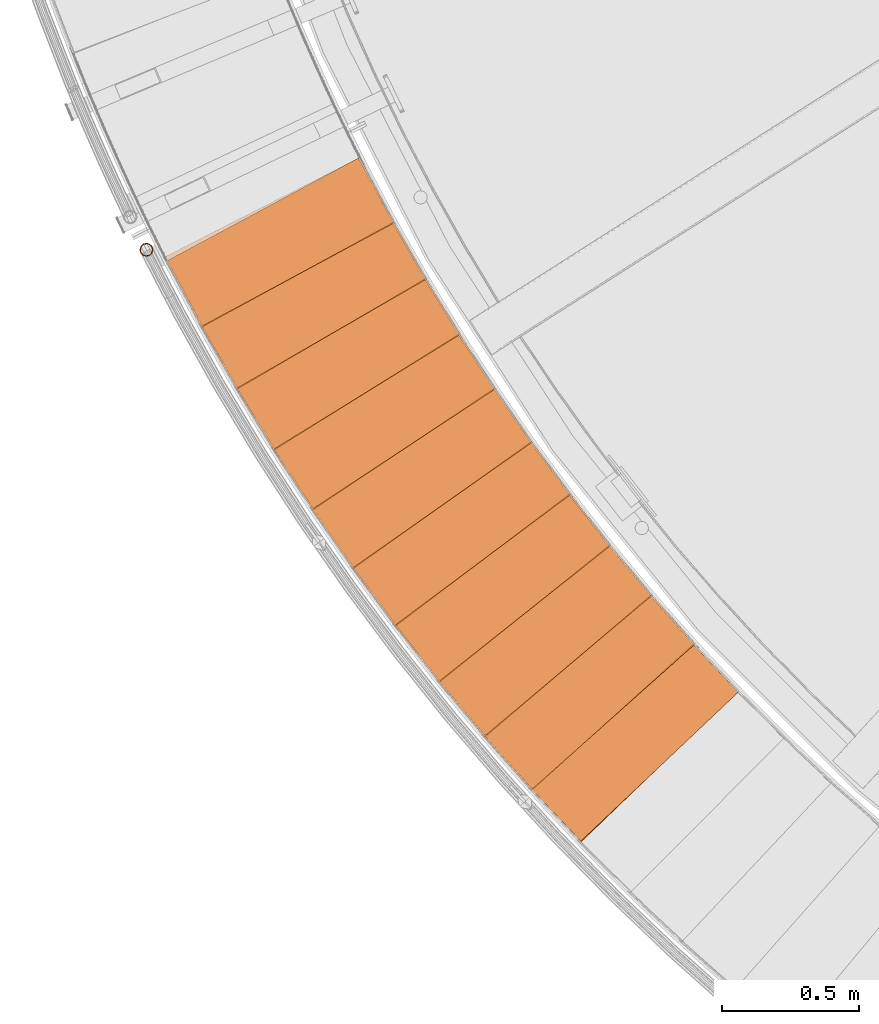
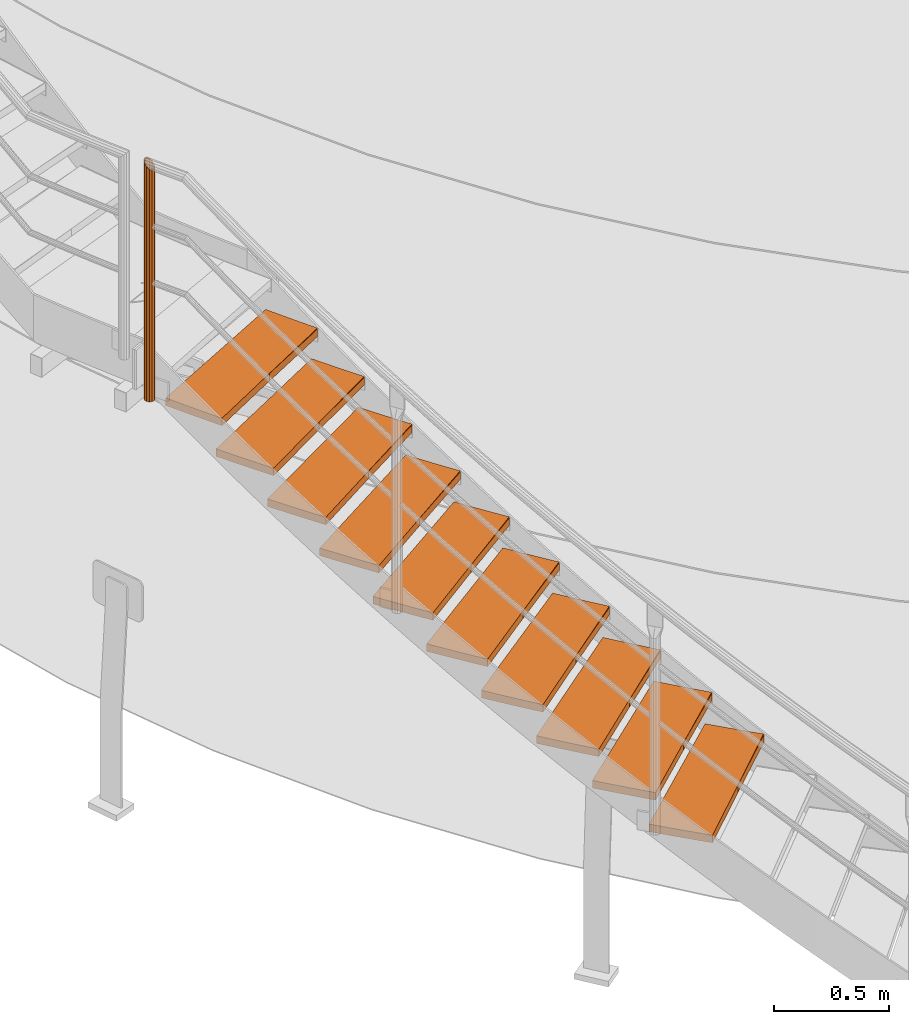
# One storey, part 3 of 126: 21 proxies.
"""IFC2X3 building model written with IfcOpenShell, lengths in millimetres."""

from ifc_helpers import new_model, si_unit, origin, origin_with_axes, place, context, project, spatial, faceted_brep, material, element, save


model = new_model("IFC2X3")

# Units and contexts
context_of_model_1 = context(None, 3, precision=0.1, world=origin())
context_of_model_2 = context(None, 3, precision=0.1, world=origin())
ifc_project = project(units=[si_unit("LENGTHUNIT", "METRE", prefix="MILLI"), si_unit("AREAUNIT", "SQUARE_METRE", prefix="CENTI"), si_unit("VOLUMEUNIT", "CUBIC_METRE", prefix="CENTI"), si_unit("MASSUNIT", "GRAM", prefix="KILO")], contexts=[context_of_model_1, context_of_model_2])

# Site, building, storey
site_placement = place(None, origin_with_axes())
site = spatial("IfcSite", under=ifc_project, at=site_placement, CompositionType="ELEMENT")
building_placement = place(site_placement, origin_with_axes())
building = spatial("IfcBuilding", under=site, at=building_placement, CompositionType="ELEMENT")
storey_placement = place(building_placement, origin_with_axes())
storey = spatial("IfcBuildingStorey", under=building, at=storey_placement, CompositionType="ELEMENT")

# Proxies
ifc_material_1 = material(Name="HOLZ")
proxy_1_placement = place(storey_placement, origin_with_axes())
element("IfcBuildingElementProxy", 1, at=proxy_1_placement, inside=storey, material=ifc_material_1, context=context_of_model_2, shape_type="Brep", body=[
    faceted_brep([(1456.3035, 2101.2672, 1039.2375), (1473.9581, 2081.7425, 1039.2375), (1491.671, 2062.2706, 1039.2375), (1509.442, 2042.8516, 1039.2375), (1527.2708, 2023.4858, 1039.2375), (1545.1574, 2004.1733, 1039.2375), (1563.1016, 1984.9143, 1039.2375), (1581.1032, 1965.7089, 1039.2375), (1599.162, 1946.5574, 1039.2375), (1617.2779, 1927.4599, 1039.2375), (1635.4508, 1908.4165, 1039.2375), (1653.6804, 1889.4275, 1039.2375), (2229.9599, 2444.3167, 1039.2375), (2211.5414, 2463.5088, 1039.2375), (2193.1867, 2482.7619, 1039.2375), (2174.896, 2502.0758, 1039.2375), (2156.6695, 2521.4503, 1039.2375), (2138.5074, 2540.8851, 1039.2375), (2120.4098, 2560.3802, 1039.2375), (2102.377, 2579.9351, 1039.2375), (2084.4092, 2599.5498, 1039.2375), (2066.5066, 2619.224, 1039.2375), (2048.6694, 2638.9574, 1039.2375), (1456.3035, 2101.2672, 999.2375), (2048.6694, 2638.9574, 999.2375), (2066.5066, 2619.224, 999.2375), (2084.4092, 2599.5498, 999.2375), (2102.377, 2579.9351, 999.2375), (2120.4098, 2560.3802, 999.2375), (2138.5074, 2540.8851, 999.2375), (2156.6695, 2521.4503, 999.2375), (2174.896, 2502.0758, 999.2375), (2193.1867, 2482.7619, 999.2375), (2211.5414, 2463.5088, 999.2375), (2229.9599, 2444.3167, 999.2375), (1653.6804, 1889.4275, 999.2375), (1635.4508, 1908.4165, 999.2375), (1617.2779, 1927.4599, 999.2375), (1599.162, 1946.5574, 999.2375), (1581.1032, 1965.7089, 999.2375), (1563.1016, 1984.9143, 999.2375), (1545.1574, 2004.1733, 999.2375), (1527.2708, 2023.4858, 999.2375), (1509.442, 2042.8516, 999.2375), (1491.671, 2062.2706, 999.2375), (1473.9581, 2081.7425, 999.2375)], [[[0, 1, 2, 3, 4, 5, 6, 7, 8, 9, 10, 11, 12, 13, 14, 15, 16, 17, 18, 19, 20, 21, 22]], [[23, 24, 25, 26, 27, 28, 29, 30, 31, 32, 33, 34, 35, 36, 37, 38, 39, 40, 41, 42, 43, 44, 45]], [[0, 23, 45, 1]], [[1, 45, 44, 2]], [[2, 44, 43, 3]], [[3, 43, 42, 4]], [[4, 42, 41, 5]], [[5, 41, 40, 6]], [[6, 40, 39, 7]], [[7, 39, 38, 8]], [[8, 38, 37, 9]], [[9, 37, 36, 10]], [[10, 36, 35, 11]], [[11, 35, 34, 12]], [[12, 34, 33, 13]], [[13, 33, 32, 14]], [[14, 32, 31, 15]], [[15, 31, 30, 16]], [[16, 30, 29, 17]], [[17, 29, 28, 18]], [[18, 28, 27, 19]], [[19, 27, 26, 20]], [[20, 26, 25, 21]], [[21, 25, 24, 22]], [[22, 24, 23, 0]]]),
])
proxy_2_placement = place(storey_placement, origin_with_axes())
element("IfcBuildingElementProxy", 2, at=proxy_2_placement, inside=storey, material=ifc_material_1, context=context_of_model_2, shape_type="Brep", body=[
    faceted_brep([(1285.3726, 2296.5769, 1212.4437), (1302.445, 2276.541, 1212.4437), (1319.5771, 2256.5561, 1212.4437), (1336.7688, 2236.6225, 1212.4437), (1354.0199, 2216.7403, 1212.4437), (1371.3303, 2196.9097, 1212.4437), (1388.6998, 2177.1309, 1212.4437), (1406.1283, 2157.404, 1212.4437), (1423.6156, 2137.7292, 1212.4437), (1441.1616, 2118.1068, 1212.4437), (1458.7661, 2098.5368, 1212.4437), (1476.4289, 2079.0194, 1212.4437), (2068.791, 2616.7062, 1212.4437), (2050.9454, 2636.4321, 1212.4437), (2033.1654, 2656.2171, 1212.4437), (2015.4511, 2676.061, 1212.4437), (1997.8027, 2695.9636, 1212.4437), (1980.2205, 2715.9246, 1212.4437), (1962.7046, 2735.9438, 1212.4437), (1945.2552, 2756.0211, 1212.4437), (1927.8725, 2776.1561, 1212.4437), (1910.5567, 2796.3487, 1212.4437), (1893.3081, 2816.5986, 1212.4437), (1285.3726, 2296.5769, 1172.4437), (1893.3081, 2816.5986, 1172.4437), (1910.5567, 2796.3487, 1172.4437), (1927.8725, 2776.1561, 1172.4437), (1945.2552, 2756.0211, 1172.4437), (1962.7046, 2735.9438, 1172.4437), (1980.2205, 2715.9246, 1172.4437), (1997.8027, 2695.9636, 1172.4437), (2015.4511, 2676.061, 1172.4437), (2033.1654, 2656.2171, 1172.4437), (2050.9454, 2636.4321, 1172.4437), (2068.791, 2616.7062, 1172.4437), (1476.4289, 2079.0194, 1172.4437), (1458.7661, 2098.5368, 1172.4437), (1441.1616, 2118.1068, 1172.4437), (1423.6156, 2137.7292, 1172.4437), (1406.1283, 2157.404, 1172.4437), (1388.6998, 2177.1309, 1172.4437), (1371.3303, 2196.9097, 1172.4437), (1354.0199, 2216.7403, 1172.4437), (1336.7688, 2236.6225, 1172.4437), (1319.5771, 2256.5561, 1172.4437), (1302.445, 2276.541, 1172.4437)], [[[0, 1, 2, 3, 4, 5, 6, 7, 8, 9, 10, 11, 12, 13, 14, 15, 16, 17, 18, 19, 20, 21, 22]], [[23, 24, 25, 26, 27, 28, 29, 30, 31, 32, 33, 34, 35, 36, 37, 38, 39, 40, 41, 42, 43, 44, 45]], [[0, 23, 45, 1]], [[1, 45, 44, 2]], [[2, 44, 43, 3]], [[3, 43, 42, 4]], [[4, 42, 41, 5]], [[5, 41, 40, 6]], [[6, 40, 39, 7]], [[7, 39, 38, 8]], [[8, 38, 37, 9]], [[9, 37, 36, 10]], [[10, 36, 35, 11]], [[11, 35, 34, 12]], [[12, 34, 33, 13]], [[13, 33, 32, 14]], [[14, 32, 31, 15]], [[15, 31, 30, 16]], [[16, 30, 29, 17]], [[17, 29, 28, 18]], [[18, 28, 27, 19]], [[19, 27, 26, 20]], [[20, 26, 25, 21]], [[21, 25, 24, 22]], [[22, 24, 23, 0]]]),
])
proxy_3_placement = place(storey_placement, origin_with_axes())
element("IfcBuildingElementProxy", 3, at=proxy_3_placement, inside=storey, material=ifc_material_1, context=context_of_model_2, shape_type="Brep", body=[
    faceted_brep([(1120.2645, 2496.833, 1385.65), (1136.7397, 2476.3032, 1385.65), (1153.2762, 2455.8228, 1385.65), (1169.8737, 2435.3918, 1385.65), (1186.5321, 2415.0105, 1385.65), (1203.2514, 2394.679, 1385.65), (1220.0312, 2374.3974, 1385.65), (1236.8715, 2354.1661, 1385.65), (1253.7721, 2333.9852, 1385.65), (1270.733, 2313.8548, 1385.65), (1287.7538, 2293.7751, 1385.65), (1304.8345, 2273.7463, 1385.65), (1912.7661, 2793.7648, 1385.65), (1895.5088, 2814.0074, 1385.65), (1878.3188, 2834.3072, 1385.65), (1861.1962, 2854.6639, 1385.65), (1844.1413, 2875.0773, 1385.65), (1827.1542, 2895.5471, 1385.65), (1810.2351, 2916.0733, 1385.65), (1793.3843, 2936.6554, 1385.65), (1776.6018, 2957.2933, 1385.65), (1759.8878, 2977.9869, 1385.65), (1743.2427, 2998.7357, 1385.65), (1120.2645, 2496.833, 1345.65), (1743.2427, 2998.7357, 1345.65), (1759.8878, 2977.9869, 1345.65), (1776.6018, 2957.2933, 1345.65), (1793.3843, 2936.6554, 1345.65), (1810.2351, 2916.0733, 1345.65), (1827.1542, 2895.5471, 1345.65), (1844.1413, 2875.0773, 1345.65), (1861.1962, 2854.6639, 1345.65), (1878.3188, 2834.3072, 1345.65), (1895.5088, 2814.0074, 1345.65), (1912.7661, 2793.7648, 1345.65), (1304.8345, 2273.7463, 1345.65), (1287.7538, 2293.7751, 1345.65), (1270.733, 2313.8548, 1345.65), (1253.7721, 2333.9852, 1345.65), (1236.8715, 2354.1661, 1345.65), (1220.0312, 2374.3974, 1345.65), (1203.2514, 2394.679, 1345.65), (1186.5321, 2415.0105, 1345.65), (1169.8737, 2435.3918, 1345.65), (1153.2762, 2455.8228, 1345.65), (1136.7397, 2476.3032, 1345.65)], [[[0, 1, 2, 3, 4, 5, 6, 7, 8, 9, 10, 11, 12, 13, 14, 15, 16, 17, 18, 19, 20, 21, 22]], [[23, 24, 25, 26, 27, 28, 29, 30, 31, 32, 33, 34, 35, 36, 37, 38, 39, 40, 41, 42, 43, 44, 45]], [[0, 23, 45, 1]], [[1, 45, 44, 2]], [[2, 44, 43, 3]], [[3, 43, 42, 4]], [[4, 42, 41, 5]], [[5, 41, 40, 6]], [[6, 40, 39, 7]], [[7, 39, 38, 8]], [[8, 38, 37, 9]], [[9, 37, 36, 10]], [[10, 36, 35, 11]], [[11, 35, 34, 12]], [[12, 34, 33, 13]], [[13, 33, 32, 14]], [[14, 32, 31, 15]], [[15, 31, 30, 16]], [[16, 30, 29, 17]], [[17, 29, 28, 18]], [[18, 28, 27, 19]], [[19, 27, 26, 20]], [[20, 26, 25, 21]], [[21, 25, 24, 22]], [[22, 24, 23, 0]]]),
])
proxy_4_placement = place(storey_placement, origin_with_axes())
element("IfcBuildingElementProxy", 4, at=proxy_4_placement, inside=storey, material=ifc_material_1, context=context_of_model_2, shape_type="Brep", body=[
    faceted_brep([(961.1222, 2701.862, 1558.8563), (976.986, 2680.8563, 1558.8563), (992.9125, 2659.898, 1558.8563), (1008.9015, 2638.9873, 1558.8563), (1024.9528, 2618.1245, 1558.8563), (1041.0663, 2597.3097, 1558.8563), (1057.2419, 2576.5431, 1558.8563), (1073.4795, 2555.8248, 1558.8563), (1089.7788, 2535.1552, 1558.8563), (1106.1397, 2514.5343, 1558.8563), (1122.5622, 2493.9623, 1558.8563), (1139.046, 2473.4395, 1558.8563), (1762.0201, 2975.339, 1558.8563), (1745.3662, 2996.0808, 1558.8563), (1728.7811, 3016.8778, 1558.8563), (1712.2651, 3037.7296, 1558.8563), (1695.8185, 3058.6362, 1558.8563), (1679.4412, 3079.5972, 1558.8563), (1663.1336, 3100.6124, 1558.8563), (1646.8959, 3121.6816, 1558.8563), (1630.7281, 3142.8046, 1558.8563), (1614.6305, 3163.9811, 1558.8563), (1598.6032, 3185.2109, 1558.8563), (961.1222, 2701.862, 1518.8563), (1598.6032, 3185.2109, 1518.8563), (1614.6305, 3163.9811, 1518.8563), (1630.7281, 3142.8046, 1518.8563), (1646.8959, 3121.6816, 1518.8563), (1663.1336, 3100.6124, 1518.8563), (1679.4412, 3079.5972, 1518.8563), (1695.8185, 3058.6362, 1518.8563), (1712.2651, 3037.7296, 1518.8563), (1728.7811, 3016.8778, 1518.8563), (1745.3662, 2996.0808, 1518.8563), (1762.0201, 2975.339, 1518.8563), (1139.046, 2473.4395, 1518.8563), (1122.5622, 2493.9623, 1518.8563), (1106.1397, 2514.5343, 1518.8563), (1089.7788, 2535.1552, 1518.8563), (1073.4795, 2555.8248, 1518.8563), (1057.2419, 2576.5431, 1518.8563), (1041.0663, 2597.3097, 1518.8563), (1024.9528, 2618.1245, 1518.8563), (1008.9015, 2638.9873, 1518.8563), (992.9125, 2659.898, 1518.8563), (976.986, 2680.8563, 1518.8563)], [[[0, 1, 2, 3, 4, 5, 6, 7, 8, 9, 10, 11, 12, 13, 14, 15, 16, 17, 18, 19, 20, 21, 22]], [[23, 24, 25, 26, 27, 28, 29, 30, 31, 32, 33, 34, 35, 36, 37, 38, 39, 40, 41, 42, 43, 44, 45]], [[0, 23, 45, 1]], [[1, 45, 44, 2]], [[2, 44, 43, 3]], [[3, 43, 42, 4]], [[4, 42, 41, 5]], [[5, 41, 40, 6]], [[6, 40, 39, 7]], [[7, 39, 38, 8]], [[8, 38, 37, 9]], [[9, 37, 36, 10]], [[10, 36, 35, 11]], [[11, 35, 34, 12]], [[12, 34, 33, 13]], [[13, 33, 32, 14]], [[14, 32, 31, 15]], [[15, 31, 30, 16]], [[16, 30, 29, 17]], [[17, 29, 28, 18]], [[18, 28, 27, 19]], [[19, 27, 26, 20]], [[20, 26, 25, 21]], [[21, 25, 24, 22]], [[22, 24, 23, 0]]]),
])
proxy_5_placement = place(storey_placement, origin_with_axes())
element("IfcBuildingElementProxy", 5, at=proxy_5_placement, inside=storey, material=ifc_material_1, context=context_of_model_2, shape_type="Brep", body=[
    faceted_brep([(808.0836, 2911.4864, 1732.0625), (823.3222, 2890.0228, 1732.0625), (838.6249, 2868.6048, 1732.0625), (853.9915, 2847.2326, 1732.0625), (869.4218, 2825.9064, 1732.0625), (884.9157, 2804.6263, 1732.0625), (900.4731, 2783.3926, 1732.0625), (916.0938, 2762.2054, 1732.0625), (931.7776, 2741.0649, 1732.0625), (947.5245, 2719.9714, 1732.0625), (963.3344, 2698.925, 1732.0625), (979.207, 2677.9259, 1732.0625), (1616.6839, 3161.2716, 1732.0625), (1600.6477, 3182.4946, 1732.0625), (1584.6819, 3203.7707, 1732.0625), (1568.7869, 3225.0996, 1732.0625), (1552.9626, 3246.4812, 1732.0625), (1537.2095, 3267.9152, 1732.0625), (1521.5275, 3289.4013, 1732.0625), (1505.9169, 3310.9393, 1732.0625), (1490.3779, 3332.529, 1732.0625), (1474.9105, 3354.1701, 1732.0625), (1459.5151, 3375.8624, 1732.0625), (808.0836, 2911.4864, 1692.0625), (1459.5151, 3375.8624, 1692.0625), (1474.9105, 3354.1701, 1692.0625), (1490.3779, 3332.529, 1692.0625), (1505.9169, 3310.9393, 1692.0625), (1521.5275, 3289.4013, 1692.0625), (1537.2095, 3267.9152, 1692.0625), (1552.9626, 3246.4812, 1692.0625), (1568.7869, 3225.0996, 1692.0625), (1584.6819, 3203.7707, 1692.0625), (1600.6477, 3182.4946, 1692.0625), (1616.6839, 3161.2716, 1692.0625), (979.207, 2677.9259, 1692.0625), (963.3344, 2698.925, 1692.0625), (947.5245, 2719.9714, 1692.0625), (931.7776, 2741.0649, 1692.0625), (916.0938, 2762.2054, 1692.0625), (900.4731, 2783.3926, 1692.0625), (884.9157, 2804.6263, 1692.0625), (869.4218, 2825.9064, 1692.0625), (853.9915, 2847.2326, 1692.0625), (838.6249, 2868.6048, 1692.0625), (823.3222, 2890.0228, 1692.0625)], [[[0, 1, 2, 3, 4, 5, 6, 7, 8, 9, 10, 11, 12, 13, 14, 15, 16, 17, 18, 19, 20, 21, 22]], [[23, 24, 25, 26, 27, 28, 29, 30, 31, 32, 33, 34, 35, 36, 37, 38, 39, 40, 41, 42, 43, 44, 45]], [[0, 23, 45, 1]], [[1, 45, 44, 2]], [[2, 44, 43, 3]], [[3, 43, 42, 4]], [[4, 42, 41, 5]], [[5, 41, 40, 6]], [[6, 40, 39, 7]], [[7, 39, 38, 8]], [[8, 38, 37, 9]], [[9, 37, 36, 10]], [[10, 36, 35, 11]], [[11, 35, 34, 12]], [[12, 34, 33, 13]], [[13, 33, 32, 14]], [[14, 32, 31, 15]], [[15, 31, 30, 16]], [[16, 30, 29, 17]], [[17, 29, 28, 18]], [[18, 28, 27, 19]], [[19, 27, 26, 20]], [[20, 26, 25, 21]], [[21, 25, 24, 22]], [[22, 24, 23, 0]]]),
])
proxy_6_placement = place(storey_placement, origin_with_axes())
element("IfcBuildingElementProxy", 6, at=proxy_6_placement, inside=storey, material=ifc_material_1, context=context_of_model_2, shape_type="Brep", body=[
    faceted_brep([(661.2812, 3125.5244, 1905.2688), (675.8816, 3103.6216, 1905.2688), (690.5472, 3081.7625, 1905.2688), (705.2781, 3059.9472, 1905.2688), (720.074, 3038.1761, 1905.2688), (734.9348, 3016.4492, 1905.2688), (749.8605, 2994.7667, 1905.2688), (764.8508, 2973.129, 1905.2688), (779.9056, 2951.536, 1905.2688), (795.0248, 2929.9882, 1905.2688), (810.2083, 2908.4855, 1905.2688), (825.456, 2887.0283, 1905.2688), (1476.8833, 3351.4014, 1905.2688), (1461.4787, 3373.0872, 1905.2688), (1446.1461, 3394.824, 1905.2688), (1430.8857, 3416.6116, 1905.2688), (1415.6977, 3438.4496, 1905.2688), (1400.5822, 3460.338, 1905.2688), (1385.5395, 3482.2763, 1905.2688), (1370.5696, 3504.2645, 1905.2688), (1355.6727, 3526.3022, 1905.2688), (1340.8491, 3548.3892, 1905.2688), (1326.0988, 3570.5253, 1905.2688), (661.2812, 3125.5244, 1865.2688), (1326.0988, 3570.5253, 1865.2688), (1340.8491, 3548.3892, 1865.2688), (1355.6727, 3526.3022, 1865.2688), (1370.5696, 3504.2645, 1865.2688), (1385.5395, 3482.2763, 1865.2688), (1400.5822, 3460.338, 1865.2688), (1415.6977, 3438.4496, 1865.2688), (1430.8857, 3416.6116, 1865.2688), (1446.1461, 3394.824, 1865.2688), (1461.4787, 3373.0872, 1865.2688), (1476.8833, 3351.4014, 1865.2688), (825.456, 2887.0283, 1865.2688), (810.2083, 2908.4855, 1865.2688), (795.0248, 2929.9882, 1865.2688), (779.9056, 2951.536, 1865.2688), (764.8508, 2973.129, 1865.2688), (749.8605, 2994.7667, 1865.2688), (734.9348, 3016.4492, 1865.2688), (720.074, 3038.1761, 1865.2688), (705.2781, 3059.9472, 1865.2688), (690.5472, 3081.7625, 1865.2688), (675.8816, 3103.6216, 1865.2688)], [[[0, 1, 2, 3, 4, 5, 6, 7, 8, 9, 10, 11, 12, 13, 14, 15, 16, 17, 18, 19, 20, 21, 22]], [[23, 24, 25, 26, 27, 28, 29, 30, 31, 32, 33, 34, 35, 36, 37, 38, 39, 40, 41, 42, 43, 44, 45]], [[0, 23, 45, 1]], [[1, 45, 44, 2]], [[2, 44, 43, 3]], [[3, 43, 42, 4]], [[4, 42, 41, 5]], [[5, 41, 40, 6]], [[6, 40, 39, 7]], [[7, 39, 38, 8]], [[8, 38, 37, 9]], [[9, 37, 36, 10]], [[10, 36, 35, 11]], [[11, 35, 34, 12]], [[12, 34, 33, 13]], [[13, 33, 32, 14]], [[14, 32, 31, 15]], [[15, 31, 30, 16]], [[16, 30, 29, 17]], [[17, 29, 28, 18]], [[18, 28, 27, 19]], [[19, 27, 26, 20]], [[20, 26, 25, 21]], [[21, 25, 24, 22]], [[22, 24, 23, 0]]]),
])
proxy_7_placement = place(storey_placement, origin_with_axes())
element("IfcBuildingElementProxy", 7, at=proxy_7_placement, inside=storey, material=ifc_material_1, context=context_of_model_2, shape_type="Brep", body=[
    faceted_brep([(520.8424, 3343.7906, 2078.475), (534.7917, 3321.4676, 2078.475), (548.8076, 3299.1862, 2078.475), (562.89, 3276.9469, 2078.475), (577.0387, 3254.7496, 2078.475), (591.2536, 3232.5948, 2078.475), (605.5346, 3210.4824, 2078.475), (619.8815, 3188.4128, 2078.475), (634.2943, 3166.3861, 2078.475), (648.7727, 3144.4025, 2078.475), (663.3168, 3122.4623, 2078.475), (677.9262, 3100.5656, 2078.475), (1342.7395, 3545.5636, 2078.475), (1327.9798, 3567.6935, 2078.475), (1313.2937, 3589.8721, 2078.475), (1298.6812, 3612.0994, 2078.475), (1284.1425, 3634.3751, 2078.475), (1269.6779, 3656.6988, 2078.475), (1255.2873, 3679.0704, 2078.475), (1240.9711, 3701.4897, 2078.475), (1226.7294, 3723.9563, 2078.475), (1212.5622, 3746.4701, 2078.475), (1198.4699, 3769.0307, 2078.475), (520.8424, 3343.7906, 2038.475), (1198.4699, 3769.0307, 2038.475), (1212.5622, 3746.4701, 2038.475), (1226.7294, 3723.9563, 2038.475), (1240.9711, 3701.4897, 2038.475), (1255.2873, 3679.0704, 2038.475), (1269.6779, 3656.6988, 2038.475), (1284.1425, 3634.3751, 2038.475), (1298.6812, 3612.0994, 2038.475), (1313.2937, 3589.8721, 2038.475), (1327.9798, 3567.6935, 2038.475), (1342.7395, 3545.5636, 2038.475), (677.9262, 3100.5656, 2038.475), (663.3168, 3122.4623, 2038.475), (648.7727, 3144.4025, 2038.475), (634.2943, 3166.3861, 2038.475), (619.8815, 3188.4128, 2038.475), (605.5346, 3210.4824, 2038.475), (591.2536, 3232.5948, 2038.475), (577.0387, 3254.7496, 2038.475), (562.89, 3276.9469, 2038.475), (548.8076, 3299.1862, 2038.475), (534.7917, 3321.4676, 2038.475)], [[[0, 1, 2, 3, 4, 5, 6, 7, 8, 9, 10, 11, 12, 13, 14, 15, 16, 17, 18, 19, 20, 21, 22]], [[23, 24, 25, 26, 27, 28, 29, 30, 31, 32, 33, 34, 35, 36, 37, 38, 39, 40, 41, 42, 43, 44, 45]], [[0, 23, 45, 1]], [[1, 45, 44, 2]], [[2, 44, 43, 3]], [[3, 43, 42, 4]], [[4, 42, 41, 5]], [[5, 41, 40, 6]], [[6, 40, 39, 7]], [[7, 39, 38, 8]], [[8, 38, 37, 9]], [[9, 37, 36, 10]], [[10, 36, 35, 11]], [[11, 35, 34, 12]], [[12, 34, 33, 13]], [[13, 33, 32, 14]], [[14, 32, 31, 15]], [[15, 31, 30, 16]], [[16, 30, 29, 17]], [[17, 29, 28, 18]], [[18, 28, 27, 19]], [[19, 27, 26, 20]], [[20, 26, 25, 21]], [[21, 25, 24, 22]], [[22, 24, 23, 0]]]),
])
proxy_8_placement = place(storey_placement, origin_with_axes())
element("IfcBuildingElementProxy", 8, at=proxy_8_placement, inside=storey, material=ifc_material_1, context=context_of_model_2, shape_type="Brep", body=[
    faceted_brep([(386.8888, 3566.0959, 2251.6813), (400.175, 3543.3719, 2251.6813), (413.529, 3520.6877, 2251.6813), (426.9507, 3498.0435, 2251.6813), (440.4399, 3475.4394, 2251.6813), (453.9966, 3452.8757, 2251.6813), (467.6205, 3430.3526, 2251.6813), (481.3117, 3407.8703, 2251.6813), (495.0699, 3385.4289, 2251.6813), (508.895, 3363.0287, 2251.6813), (522.7869, 3340.6699, 2251.6813), (536.7456, 3318.3527, 2251.6813), (1214.3687, 3743.5901, 2251.6813), (1200.2668, 3766.1448, 2251.6813), (1186.2398, 3788.7461, 2251.6813), (1172.2879, 3811.3938, 2251.6813), (1158.4111, 3834.0878, 2251.6813), (1144.6098, 3856.8276, 2251.6813), (1130.884, 3879.6131, 2251.6813), (1117.2339, 3902.444, 2251.6813), (1103.6596, 3925.3201, 2251.6813), (1090.1612, 3948.2411, 2251.6813), (1076.739, 3971.2067, 2251.6813), (386.8888, 3566.0959, 2211.6813), (1076.739, 3971.2067, 2211.6813), (1090.1612, 3948.2411, 2211.6813), (1103.6596, 3925.3201, 2211.6813), (1117.2339, 3902.444, 2211.6813), (1130.884, 3879.6131, 2211.6813), (1144.6098, 3856.8276, 2211.6813), (1158.4111, 3834.0878, 2211.6813), (1172.2879, 3811.3938, 2211.6813), (1186.2398, 3788.7461, 2211.6813), (1200.2668, 3766.1448, 2211.6813), (1214.3687, 3743.5901, 2211.6813), (536.7456, 3318.3527, 2211.6813), (522.7869, 3340.6699, 2211.6813), (508.895, 3363.0287, 2211.6813), (495.0699, 3385.4289, 2211.6813), (481.3117, 3407.8703, 2211.6813), (467.6205, 3430.3526, 2211.6813), (453.9966, 3452.8757, 2211.6813), (440.4399, 3475.4394, 2211.6813), (426.9507, 3498.0435, 2211.6813), (413.529, 3520.6877, 2211.6813), (400.175, 3543.3719, 2211.6813)], [[[0, 1, 2, 3, 4, 5, 6, 7, 8, 9, 10, 11, 12, 13, 14, 15, 16, 17, 18, 19, 20, 21, 22]], [[23, 24, 25, 26, 27, 28, 29, 30, 31, 32, 33, 34, 35, 36, 37, 38, 39, 40, 41, 42, 43, 44, 45]], [[0, 23, 45, 1]], [[1, 45, 44, 2]], [[2, 44, 43, 3]], [[3, 43, 42, 4]], [[4, 42, 41, 5]], [[5, 41, 40, 6]], [[6, 40, 39, 7]], [[7, 39, 38, 8]], [[8, 38, 37, 9]], [[9, 37, 36, 10]], [[10, 36, 35, 11]], [[11, 35, 34, 12]], [[12, 34, 33, 13]], [[13, 33, 32, 14]], [[14, 32, 31, 15]], [[15, 31, 30, 16]], [[16, 30, 29, 17]], [[17, 29, 28, 18]], [[18, 28, 27, 19]], [[19, 27, 26, 20]], [[20, 26, 25, 21]], [[21, 25, 24, 22]], [[22, 24, 23, 0]]]),
])
proxy_9_placement = place(storey_placement, origin_with_axes())
element("IfcBuildingElementProxy", 9, at=proxy_9_placement, inside=storey, material=ifc_material_1, context=context_of_model_2, shape_type="Brep", body=[
    faceted_brep([(259.5365, 3792.2475, 2424.8875), (272.1481, 3769.1424, 2424.8875), (284.8286, 3746.0749, 2424.8875), (297.578, 3723.0455, 2424.8875), (310.3961, 3700.0542, 2424.8875), (323.2827, 3677.1012, 2424.8875), (336.2378, 3654.1869, 2424.8875), (349.2613, 3631.3113, 2424.8875), (362.353, 3608.4747, 2424.8875), (375.5128, 3585.6773, 2424.8875), (388.7406, 3562.9193, 2424.8875), (402.0363, 3540.2009, 2424.8875), (1091.8822, 3945.3092, 2424.8875), (1078.4502, 3968.2691, 2424.8875), (1065.0945, 3991.2735, 2424.8875), (1051.8152, 4014.3221, 2424.8875), (1038.6125, 4037.4146, 2424.8875), (1025.4865, 4060.5509, 2424.8875), (1012.4373, 4083.7305, 2424.8875), (999.465, 4106.9533, 2424.8875), (986.5699, 4130.219, 2424.8875), (973.7521, 4153.5274, 2424.8875), (961.0117, 4176.8781, 2424.8875), (259.5365, 3792.2475, 2384.8875), (961.0117, 4176.8781, 2384.8875), (973.7521, 4153.5274, 2384.8875), (986.5699, 4130.219, 2384.8875), (999.465, 4106.9533, 2384.8875), (1012.4373, 4083.7305, 2384.8875), (1025.4865, 4060.5509, 2384.8875), (1038.6125, 4037.4146, 2384.8875), (1051.8152, 4014.3221, 2384.8875), (1065.0945, 3991.2735, 2384.8875), (1078.4502, 3968.2691, 2384.8875), (1091.8822, 3945.3092, 2384.8875), (402.0363, 3540.2009, 2384.8875), (388.7406, 3562.9193, 2384.8875), (375.5128, 3585.6773, 2384.8875), (362.353, 3608.4747, 2384.8875), (349.2613, 3631.3113, 2384.8875), (336.2378, 3654.1869, 2384.8875), (323.2827, 3677.1012, 2384.8875), (310.3961, 3700.0542, 2384.8875), (297.578, 3723.0455, 2384.8875), (284.8286, 3746.0749, 2384.8875), (272.1481, 3769.1424, 2384.8875)], [[[0, 1, 2, 3, 4, 5, 6, 7, 8, 9, 10, 11, 12, 13, 14, 15, 16, 17, 18, 19, 20, 21, 22]], [[23, 24, 25, 26, 27, 28, 29, 30, 31, 32, 33, 34, 35, 36, 37, 38, 39, 40, 41, 42, 43, 44, 45]], [[0, 23, 45, 1]], [[1, 45, 44, 2]], [[2, 44, 43, 3]], [[3, 43, 42, 4]], [[4, 42, 41, 5]], [[5, 41, 40, 6]], [[6, 40, 39, 7]], [[7, 39, 38, 8]], [[8, 38, 37, 9]], [[9, 37, 36, 10]], [[10, 36, 35, 11]], [[11, 35, 34, 12]], [[12, 34, 33, 13]], [[13, 33, 32, 14]], [[14, 32, 31, 15]], [[15, 31, 30, 16]], [[16, 30, 29, 17]], [[17, 29, 28, 18]], [[18, 28, 27, 19]], [[19, 27, 26, 20]], [[20, 26, 25, 21]], [[21, 25, 24, 22]], [[22, 24, 23, 0]]]),
])
proxy_10_placement = place(storey_placement, origin_with_axes())
element("IfcBuildingElementProxy", 10, at=proxy_10_placement, inside=storey, material=ifc_material_1, context=context_of_model_2, shape_type="Brep", body=[
    faceted_brep([(138.8958, 4022.0497, 2598.0938), (150.8219, 3998.5833, 2598.0938), (162.818, 3975.1526, 2598.0938), (174.884, 3951.7579, 2598.0938), (187.0197, 3928.3993, 2598.0938), (199.2252, 3905.077, 2598.0938), (211.5003, 3881.7912, 2598.0938), (223.8448, 3858.5422, 2598.0938), (236.2586, 3835.3302, 2598.0938), (248.7417, 3812.1553, 2598.0938), (261.294, 3789.0178, 2598.0938), (273.9152, 3765.9179, 2598.0938), (975.386, 4150.5461, 2598.0938), (962.6357, 4173.8914, 2598.0938), (949.9629, 4197.279, 2598.0938), (937.3677, 4220.7084, 2598.0938), (924.8504, 4244.1796, 2598.0938), (912.411, 4267.6921, 2598.0938), (900.0497, 4291.2457, 2598.0938), (887.7667, 4314.8403, 2598.0938), (875.5619, 4338.4755, 2598.0938), (863.4357, 4362.151, 2598.0938), (851.3881, 4385.8667, 2598.0938), (138.8958, 4022.0497, 2558.0938), (851.3881, 4385.8667, 2558.0938), (863.4357, 4362.151, 2558.0938), (875.5619, 4338.4755, 2558.0938), (887.7667, 4314.8403, 2558.0938), (900.0497, 4291.2457, 2558.0938), (912.411, 4267.6921, 2558.0938), (924.8504, 4244.1796, 2558.0938), (937.3677, 4220.7084, 2558.0938), (949.9629, 4197.279, 2558.0938), (962.6357, 4173.8914, 2558.0938), (975.386, 4150.5461, 2558.0938), (273.9152, 3765.9179, 2558.0938), (261.294, 3789.0178, 2558.0938), (248.7417, 3812.1553, 2558.0938), (236.2586, 3835.3302, 2558.0938), (223.8448, 3858.5422, 2558.0938), (211.5003, 3881.7912, 2558.0938), (199.2252, 3905.077, 2558.0938), (187.0197, 3928.3993, 2558.0938), (174.884, 3951.7579, 2558.0938), (162.818, 3975.1526, 2558.0938), (150.8219, 3998.5833, 2558.0938)], [[[0, 1, 2, 3, 4, 5, 6, 7, 8, 9, 10, 11, 12, 13, 14, 15, 16, 17, 18, 19, 20, 21, 22]], [[23, 24, 25, 26, 27, 28, 29, 30, 31, 32, 33, 34, 35, 36, 37, 38, 39, 40, 41, 42, 43, 44, 45]], [[0, 23, 45, 1]], [[1, 45, 44, 2]], [[2, 44, 43, 3]], [[3, 43, 42, 4]], [[4, 42, 41, 5]], [[5, 41, 40, 6]], [[6, 40, 39, 7]], [[7, 39, 38, 8]], [[8, 38, 37, 9]], [[9, 37, 36, 10]], [[10, 36, 35, 11]], [[11, 35, 34, 12]], [[12, 34, 33, 13]], [[13, 33, 32, 14]], [[14, 32, 31, 15]], [[15, 31, 30, 16]], [[16, 30, 29, 17]], [[17, 29, 28, 18]], [[18, 28, 27, 19]], [[19, 27, 26, 20]], [[20, 26, 25, 21]], [[21, 25, 24, 22]], [[22, 24, 23, 0]]]),
])
ifc_material_2 = material(Name="S235JRG2")
proxy_11_placement = place(storey_placement, origin_with_axes())
element("IfcBuildingElementProxy", 11, at=proxy_11_placement, inside=storey, material=ifc_material_2, context=context_of_model_2, shape_type="Brep", body=[
    faceted_brep([(1654.9049, 1895.3858, 999.01), (1654.9049, 1895.3858, 1039.01), (1469.3341, 2091.5069, 1039.01), (1469.3341, 2091.5069, 999.01), (2228.7405, 2438.3524, 999.01), (2043.1697, 2634.4734, 999.01), (2043.1697, 2634.4734, 1039.01), (2228.7405, 2438.3524, 1039.01)], [[[0, 1, 2, 3]], [[4, 5, 6, 7]], [[0, 4, 7, 1]], [[1, 7, 6, 2]], [[2, 6, 5, 3]], [[3, 5, 4, 0]]]),
])
proxy_12_placement = place(storey_placement, origin_with_axes())
element("IfcBuildingElementProxy", 12, at=proxy_12_placement, inside=storey, material=ifc_material_2, context=context_of_model_2, shape_type="Brep", body=[
    faceted_brep([(1477.8287, 2084.9385, 1172.17), (1477.8287, 2084.9385, 1212.17), (1298.1108, 2286.4366, 1212.17), (1298.1108, 2286.4366, 1172.17), (2067.3971, 2610.7798, 1172.17), (1887.6792, 2812.2779, 1172.17), (1887.6792, 2812.2779, 1212.17), (2067.3971, 2610.7798, 1212.17)], [[[0, 1, 2, 3]], [[4, 5, 6, 7]], [[0, 4, 7, 1]], [[1, 7, 6, 2]], [[2, 6, 5, 3]], [[3, 5, 4, 0]]]),
])
proxy_13_placement = place(storey_placement, origin_with_axes())
element("IfcBuildingElementProxy", 13, at=proxy_13_placement, inside=storey, material=ifc_material_2, context=context_of_model_2, shape_type="Brep", body=[
    faceted_brep([(1306.4084, 2279.6211, 1345.33), (1306.4084, 2279.6211, 1385.33), (1132.6992, 2486.3216, 1385.33), (1132.6992, 2486.3216, 1345.33), (1911.1988, 2787.8815, 1345.33), (1737.4895, 2994.582, 1345.33), (1737.4895, 2994.582, 1385.33), (1911.1988, 2787.8815, 1385.33)], [[[0, 1, 2, 3]], [[4, 5, 6, 7]], [[0, 4, 7, 1]], [[1, 7, 6, 2]], [[2, 6, 5, 3]], [[3, 5, 4, 0]]]),
])
proxy_14_placement = place(storey_placement, origin_with_axes())
element("IfcBuildingElementProxy", 14, at=proxy_14_placement, inside=storey, material=ifc_material_2, context=context_of_model_2, shape_type="Brep", body=[
    faceted_brep([(1140.7926, 2479.2648, 1518.49), (1140.7926, 2479.2648, 1558.49), (973.2425, 2690.9886, 1558.49), (973.2425, 2690.9886, 1518.49), (1760.2808, 2969.5039, 1518.49), (1592.7308, 3181.2277, 1518.49), (1592.7308, 3181.2277, 1558.49), (1760.2808, 2969.5039, 1558.49)], [[[0, 1, 2, 3]], [[4, 5, 6, 7]], [[0, 4, 7, 1]], [[1, 7, 6, 2]], [[2, 6, 5, 3]], [[3, 5, 4, 0]]]),
])
proxy_15_placement = place(storey_placement, origin_with_axes())
element("IfcBuildingElementProxy", 15, at=proxy_15_placement, inside=storey, material=ifc_material_2, context=context_of_model_2, shape_type="Brep", body=[
    faceted_brep([(981.1248, 2683.6966, 1691.65), (981.1248, 2683.6966, 1731.65), (819.8791, 2900.2603, 1731.65), (819.8791, 2900.2603, 1691.65), (1614.774, 3155.4896, 1691.65), (1453.5283, 3372.0533, 1691.65), (1453.5283, 3372.0533, 1731.65), (1614.774, 3155.4896, 1731.65)], [[[0, 1, 2, 3]], [[4, 5, 6, 7]], [[0, 4, 7, 1]], [[1, 7, 6, 2]], [[2, 6, 5, 3]], [[3, 5, 4, 0]]]),
])
proxy_16_placement = place(storey_placement, origin_with_axes())
element("IfcBuildingElementProxy", 16, at=proxy_16_placement, inside=storey, material=ifc_material_2, context=context_of_model_2, shape_type="Brep", body=[
    faceted_brep([(827.5432, 2892.7395, 1864.81), (827.5432, 2892.7395, 1904.81), (672.7416, 3113.9554, 1904.81), (672.7416, 3113.9554, 1864.81), (1474.8045, 3345.6775, 1864.81), (1320.0029, 3566.8934, 1864.81), (1320.0029, 3566.8934, 1904.81), (1474.8045, 3345.6775, 1904.81)], [[[0, 1, 2, 3]], [[4, 5, 6, 7]], [[0, 4, 7, 1]], [[1, 7, 6, 2]], [[2, 6, 5, 3]], [[3, 5, 4, 0]]]),
])
proxy_17_placement = place(storey_placement, origin_with_axes())
element("IfcBuildingElementProxy", 17, at=proxy_17_placement, inside=storey, material=ifc_material_2, context=context_of_model_2, shape_type="Brep", body=[
    faceted_brep([(680.1811, 3106.2123, 2037.97), (680.1811, 3106.2123, 2077.97), (531.9578, 3331.8886, 2077.97), (531.9578, 3331.8886, 2037.97), (1340.4935, 3539.9029, 2037.97), (1192.2702, 3765.5792, 2037.97), (1192.2702, 3765.5792, 2077.97), (1340.4935, 3539.9029, 2077.97)], [[[0, 1, 2, 3]], [[4, 5, 6, 7]], [[0, 4, 7, 1]], [[1, 7, 6, 2]], [[2, 6, 5, 3]], [[3, 5, 4, 0]]]),
])
proxy_18_placement = place(storey_placement, origin_with_axes())
element("IfcBuildingElementProxy", 18, at=proxy_18_placement, inside=storey, material=ifc_material_2, context=context_of_model_2, shape_type="Brep", body=[
    faceted_brep([(539.1661, 3323.9299, 2211.13), (539.1661, 3323.9299, 2251.13), (397.6494, 3553.8712, 2251.13), (397.6494, 3553.8712, 2211.13), (1211.9575, 3737.9973, 2211.13), (1070.4408, 3967.9386, 2211.13), (1070.4408, 3967.9386, 2251.13), (1211.9575, 3737.9973, 2251.13)], [[[0, 1, 2, 3]], [[4, 5, 6, 7]], [[0, 4, 7, 1]], [[1, 7, 6, 2]], [[2, 6, 5, 3]], [[3, 5, 4, 0]]]),
])
proxy_19_placement = place(storey_placement, origin_with_axes())
element("IfcBuildingElementProxy", 19, at=proxy_19_placement, inside=storey, material=ifc_material_2, context=context_of_model_2, shape_type="Brep", body=[
    faceted_brep([(404.6204, 3545.7038, 2384.29), (404.6204, 3545.7038, 2424.29), (269.933, 3779.7108, 2424.29), (269.933, 3779.7108, 2384.29), (1089.3077, 3939.7891, 2384.29), (954.6203, 4173.7962, 2384.29), (954.6203, 4173.7962, 2424.29), (1089.3077, 3939.7891, 2424.29)], [[[0, 1, 2, 3]], [[4, 5, 6, 7]], [[0, 4, 7, 1]], [[1, 7, 6, 2]], [[2, 6, 5, 3]], [[3, 5, 4, 0]]]),
])
proxy_20_placement = place(storey_placement, origin_with_axes())
element("IfcBuildingElementProxy", 20, at=proxy_20_placement, inside=storey, material=ifc_material_2, context=context_of_model_2, shape_type="Brep", body=[
    faceted_brep([(276.6606, 3771.3417, 2557.45), (276.6606, 3771.3417, 2597.45), (148.9192, 4009.2117, 2597.45), (148.9192, 4009.2117, 2557.45), (972.6505, 4145.1036, 2557.45), (844.9091, 4382.9736, 2557.45), (844.9091, 4382.9736, 2597.45), (972.6505, 4145.1036, 2597.45)], [[[0, 1, 2, 3]], [[4, 5, 6, 7]], [[0, 4, 7, 1]], [[1, 7, 6, 2]], [[2, 6, 5, 3]], [[3, 5, 4, 0]]]),
])
proxy_21_placement = place(storey_placement, origin_with_axes())
element("IfcBuildingElementProxy", 21, at=proxy_21_placement, inside=storey, material=ifc_material_2, Name="HANDLAUF", context=context_of_model_2, shape_type="Brep", body=[
    faceted_brep([(62.0625, 4069.9485, 2600.05), (52.8931, 4061.4517, 2600.05), (52.8931, 4061.4517, 3867.1746), (62.0625, 4069.9485, 3870.7492), (74.2518, 4072.7224, 3867.8852), (74.2518, 4072.7224, 2600.05), (86.195, 4069.0299, 3859.3499), (86.195, 4069.0299, 2600.05), (94.6919, 4059.8605, 3847.4304), (94.6919, 4059.8605, 2600.05), (97.4657, 4047.6712, 3835.3205), (97.4657, 4047.6712, 2600.05), (93.7732, 4035.728, 3826.2651), (93.7732, 4035.728, 2600.05), (84.6039, 4027.2312, 3822.6905), (84.6039, 4027.2312, 2600.05), (72.4146, 4024.4573, 3825.5545), (72.4146, 4024.4573, 2600.05), (60.4714, 4028.1498, 3834.0898), (60.4714, 4028.1498, 2600.05), (51.9745, 4037.3192, 3846.0093), (51.9745, 4037.3192, 2600.05), (49.2007, 4049.5085, 3858.1191), (49.2007, 4049.5085, 2600.05), (51.6989, 4049.4134, 2600.05), (55.0091, 4060.1202, 2600.05), (55.0091, 4060.1202, 3865.0571), (51.6989, 4049.4134, 3856.9391), (54.1855, 4038.4859, 3846.0828), (54.1855, 4038.4859, 2600.05), (61.8028, 4030.2657, 3835.3972), (61.8028, 4030.2657, 2600.05), (72.5096, 4026.9555, 3827.7455), (72.5096, 4026.9555, 2600.05), (83.4371, 4029.4422, 3825.178), (83.4371, 4029.4422, 2600.05), (91.6573, 4037.0595, 3828.3826), (91.6573, 4037.0595, 2600.05), (94.9675, 4047.7663, 3836.5006), (94.9675, 4047.7663, 2600.05), (92.4808, 4058.6938, 3847.3569), (92.4808, 4058.6938, 2600.05), (84.8636, 4066.914, 3858.0425), (84.8636, 4066.914, 2600.05), (74.1567, 4070.2242, 3865.6942), (74.1567, 4070.2242, 2600.05), (63.2292, 4067.7375, 3868.2617), (63.2292, 4067.7375, 2600.05)], [[[0, 1, 2, 3]], [[0, 3, 4, 5]], [[5, 4, 6, 7]], [[7, 6, 8, 9]], [[9, 8, 10, 11]], [[11, 10, 12, 13]], [[13, 12, 14, 15]], [[15, 14, 16, 17]], [[17, 16, 18, 19]], [[19, 18, 20, 21]], [[21, 20, 22, 23]], [[1, 23, 22, 2]], [[24, 25, 26, 27]], [[24, 27, 28, 29]], [[29, 28, 30, 31]], [[31, 30, 32, 33]], [[33, 32, 34, 35]], [[35, 34, 36, 37]], [[37, 36, 38, 39]], [[39, 38, 40, 41]], [[41, 40, 42, 43]], [[43, 42, 44, 45]], [[45, 44, 46, 47]], [[25, 47, 46, 26]], [[19, 21, 23, 1, 0, 5, 7, 9, 11, 13, 15, 17], [24, 29, 31, 33, 35, 37, 39, 41, 43, 45, 47, 25]], [[14, 12, 10, 8, 6, 4, 3, 2, 22, 20, 18, 16], [26, 46, 44, 42, 40, 38, 36, 34, 32, 30, 28, 27]]]),
])

save(model, "model.ifc")
